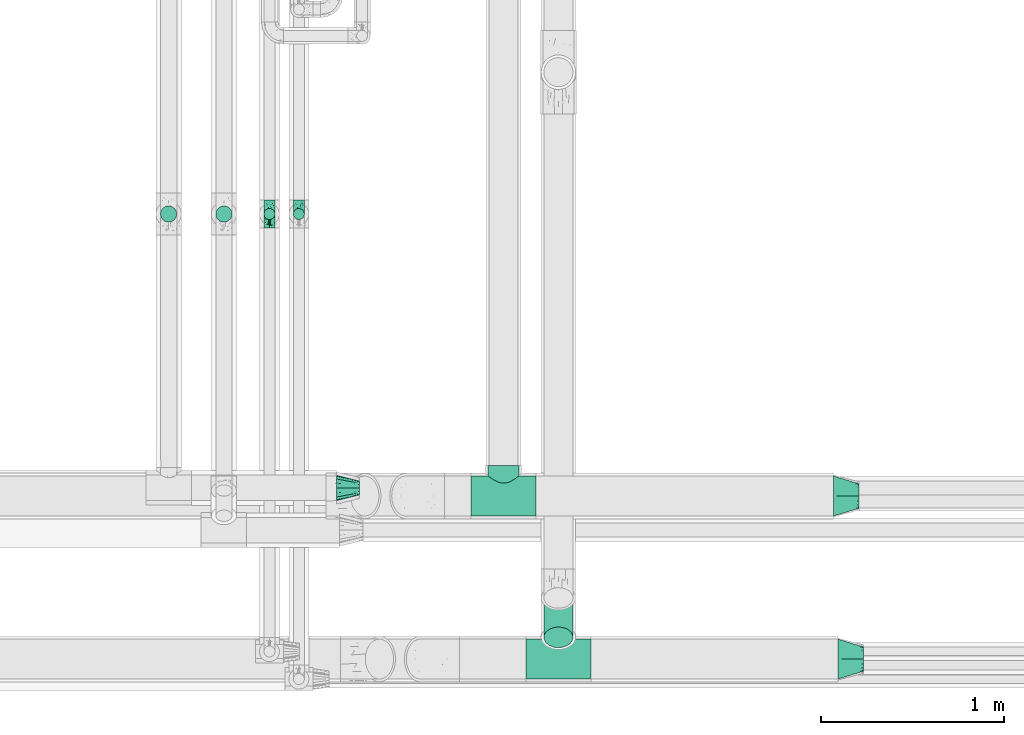
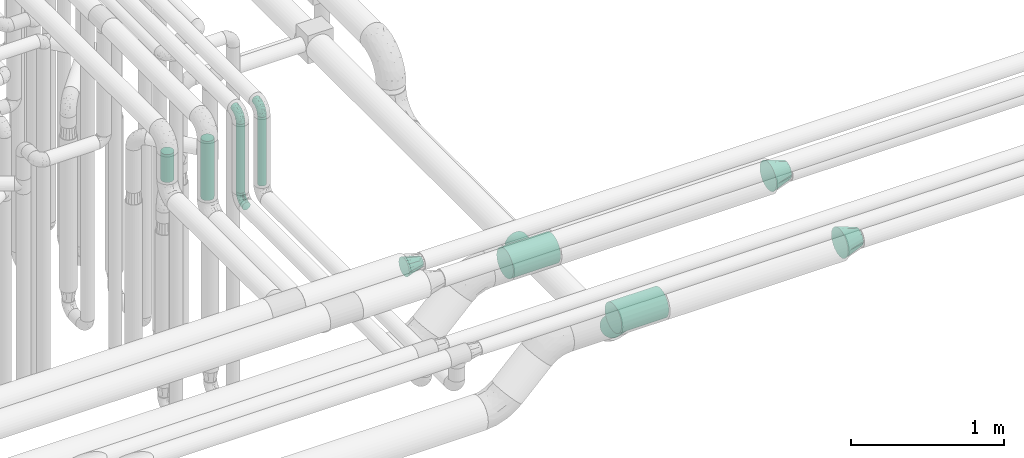
# One storey, part 604 of 824: 8 flow fittings, 5 flow segments.
"""IFC2X3 building model written with IfcOpenShell, lengths in millimetres."""

from ifc_helpers import new_model, entity, si_unit, converted_unit, derived_unit, direction, frame, origin, origin_2d_with_axis, place, context, subcontext, project, spatial, circle, extrude, faceted_brep, source, transform, mapped, material, type_object, type_shapes, element, save


model = new_model("IFC2X3")

# Units and contexts
model_context = context("Model", 3, precision=0.01, world=origin(), true_north=direction((6.12303176911189e-17, 1.0)))
body_context = subcontext(model_context, "Body", "Model", "MODEL_VIEW")
ifc_project = project(units=[si_unit("LENGTHUNIT", "METRE", prefix="MILLI"), si_unit("AREAUNIT", "SQUARE_METRE"), si_unit("VOLUMEUNIT", "CUBIC_METRE"), converted_unit("PLANEANGLEUNIT", "DEGREE", entity("IfcRatioMeasure", 0.0174532925199433), si_unit("PLANEANGLEUNIT", "RADIAN"), dimensions=[0, 0, 0, 0, 0, 0, 0]), si_unit("MASSUNIT", "GRAM", prefix="KILO"), derived_unit("MASSDENSITYUNIT", [(si_unit("MASSUNIT", "GRAM", prefix="KILO"), 1), (si_unit("LENGTHUNIT", "METRE"), -3)]), derived_unit("MOMENTOFINERTIAUNIT", [(si_unit("LENGTHUNIT", "METRE"), 4)]), si_unit("TIMEUNIT", "SECOND"), si_unit("FREQUENCYUNIT", "HERTZ"), si_unit("THERMODYNAMICTEMPERATUREUNIT", "DEGREE_CELSIUS"), derived_unit("THERMALTRANSMITTANCEUNIT", [(si_unit("MASSUNIT", "GRAM", prefix="KILO"), 1), (si_unit("THERMODYNAMICTEMPERATUREUNIT", "KELVIN"), -1), (si_unit("TIMEUNIT", "SECOND"), -3)]), derived_unit("VOLUMETRICFLOWRATEUNIT", [(si_unit("LENGTHUNIT", "METRE"), 3), (si_unit("TIMEUNIT", "SECOND"), -1)]), derived_unit("MASSFLOWRATEUNIT", [(si_unit("MASSUNIT", "GRAM", prefix="KILO"), 1), (si_unit("TIMEUNIT", "SECOND"), -1)]), derived_unit("ROTATIONALFREQUENCYUNIT", [(si_unit("TIMEUNIT", "SECOND"), -1)]), si_unit("ELECTRICCURRENTUNIT", "AMPERE"), si_unit("ELECTRICVOLTAGEUNIT", "VOLT"), si_unit("POWERUNIT", "WATT"), si_unit("FORCEUNIT", "NEWTON", prefix="KILO"), si_unit("ILLUMINANCEUNIT", "LUX"), si_unit("LUMINOUSFLUXUNIT", "LUMEN"), si_unit("LUMINOUSINTENSITYUNIT", "CANDELA"), derived_unit("USERDEFINED", [(si_unit("MASSUNIT", "GRAM", prefix="KILO"), -1), (si_unit("LENGTHUNIT", "METRE"), -2), (si_unit("TIMEUNIT", "SECOND"), 3), (si_unit("LUMINOUSFLUXUNIT", "LUMEN"), 1)]), derived_unit("LINEARVELOCITYUNIT", [(si_unit("LENGTHUNIT", "METRE"), 1), (si_unit("TIMEUNIT", "SECOND"), -1)]), si_unit("PRESSUREUNIT", "PASCAL"), derived_unit("USERDEFINED", [(si_unit("LENGTHUNIT", "METRE"), -2), (si_unit("MASSUNIT", "GRAM", prefix="KILO"), 1), (si_unit("TIMEUNIT", "SECOND"), -2)]), derived_unit("LINEARFORCEUNIT", [(si_unit("MASSUNIT", "GRAM", prefix="KILO"), 1), (si_unit("LENGTHUNIT", "METRE"), 1), (si_unit("TIMEUNIT", "SECOND"), -2), (si_unit("LENGTHUNIT", "METRE"), -1)]), derived_unit("PLANARFORCEUNIT", [(si_unit("MASSUNIT", "GRAM", prefix="KILO"), 1), (si_unit("LENGTHUNIT", "METRE"), 1), (si_unit("TIMEUNIT", "SECOND"), -2), (si_unit("LENGTHUNIT", "METRE"), -2)])], contexts=[model_context])

# Site, building, storey
site_placement = place(None, origin())
site = spatial("IfcSite", under=ifc_project, at=site_placement, CompositionType="ELEMENT")
building_placement = place(site_placement, origin())
building = spatial("IfcBuilding", under=site, at=building_placement, CompositionType="ELEMENT")
storey_placement = place(building_placement, frame((0.0, 0.0, 28200.0)))
storey = spatial("IfcBuildingStorey", under=building, at=storey_placement, CompositionType="ELEMENT", Elevation=28200.0)

# Flow segments
pipe_segment_type_1 = type_object("IfcPipeSegmentType", PredefinedType="NOTDEFINED")
flow_segment_1_placement = place(storey_placement, frame((37967.2, 6435.98, 2508.09)))
element("IfcFlowSegment", 1, at=flow_segment_1_placement, inside=storey, type_object=pipe_segment_type_1, context=body_context, shape_type="SweptSolid", body=[
    extrude(circle(Radius=79.5, at=origin_2d_with_axis()), frame((81.1, 57.81, 273.12), z_axis=(0.0, 0.707106781186546, -0.707106781186549), x_axis=(1.0, 0.0, 0.0)), (0.0, 0.0, 1.0), 304.487373415324),
])
pipe_segment_type_2 = type_object("IfcPipeSegmentType", PredefinedType="NOTDEFINED")
flow_segment_2_placement = place(storey_placement, frame((36174.19, 8761.54, 2964.0)))
element("IfcFlowSegment", 2, at=flow_segment_2_placement, inside=storey, type_object=pipe_segment_type_2, context=body_context, shape_type="SweptSolid", body=[
    extrude(circle(Radius=44.25, at=origin_2d_with_axis()), frame((45.85, 45.85, 0.0), z_axis=(0.0, 0.0, 1.0), x_axis=(-1.0, 0.0, 0.0)), (0.0, 0.0, 1.0), 472.000402937329),
])
flow_segment_3_placement = place(storey_placement, frame((35872.22, 8761.54, 3214.0)))
element("IfcFlowSegment", 3, at=flow_segment_3_placement, inside=storey, type_object=pipe_segment_type_2, context=body_context, shape_type="SweptSolid", body=[
    extrude(circle(Radius=44.25, at=origin_2d_with_axis()), frame((45.85, 45.85, 0.0)), (0.0, 0.0, 1.0), 222.001032735806),
])
flow_segment_4_placement = place(storey_placement, frame((36598.05, 8775.79, 2926.0)))
element("IfcFlowSegment", 4, at=flow_segment_4_placement, inside=storey, type_object=pipe_segment_type_2, context=body_context, shape_type="SweptSolid", body=[
    extrude(circle(Radius=30.0, at=origin_2d_with_axis()), frame((31.6, 31.6, 0.0)), (0.0, 0.0, 1.0), 547.999328702734),
])
flow_segment_5_placement = place(storey_placement, frame((36437.12, 8775.79, 2926.0)))
element("IfcFlowSegment", 5, at=flow_segment_5_placement, inside=storey, type_object=pipe_segment_type_2, context=body_context, shape_type="SweptSolid", body=[
    extrude(circle(Radius=30.0, at=origin_2d_with_axis()), frame((31.6, 31.6, 0.0), z_axis=(0.0, 0.0, 1.0), x_axis=(-1.0, 0.0, 0.0)), (0.0, 0.0, 1.0), 548.000000000049),
])

# Flow fittings
ifc_material = material()
pipe_fitting_type_1 = type_object("IfcPipeFittingType", PredefinedType="NOTDEFINED", material=ifc_material)
shared_shape_1 = source(origin(), body_context, "Body", "Brep", [
    faceted_brep([(-76.0, 15.07, -26.11), (-76.0, 7.8, -29.12), (-76.0, 0.0, -30.15), (-76.0, -7.8, -29.12), (-76.0, -15.08, -26.11), (-76.0, -21.32, -21.32), (-76.0, -26.11, -15.08), (-76.0, -29.12, -7.8), (-76.0, -30.15, 0.0), (-76.0, -29.12, 7.8), (-76.0, -26.11, 15.07), (-76.0, -21.32, 21.32), (-76.0, -15.08, 26.11), (-76.0, -7.8, 29.12), (-76.0, 0.0, 30.15), (-76.0, 7.8, 29.12), (-76.0, 15.07, 26.11), (-76.0, 21.32, 21.32), (-76.0, 26.11, 15.07), (-76.0, 29.12, 7.8), (-76.0, 30.15, 0.0), (-76.0, 29.12, -7.8), (-76.0, 26.11, -15.08), (-76.0, 21.32, -21.32), (0.0, 76.0, -30.15), (-7.8, 76.0, -29.12), (-15.07, 76.0, -26.11), (-21.32, 76.0, -21.32), (-26.11, 76.0, -15.08), (-29.12, 76.0, -7.8), (-30.15, 76.0, 0.0), (-29.12, 76.0, 7.8), (-26.11, 76.0, 15.07), (-21.32, 76.0, 21.32), (-15.07, 76.0, 26.11), (-7.8, 76.0, 29.12), (0.0, 76.0, 30.15), (7.8, 76.0, 29.12), (15.08, 76.0, 26.11), (21.32, 76.0, 21.32), (26.11, 76.0, 15.07), (29.12, 76.0, 7.8), (30.15, 76.0, 0.0), (29.12, 76.0, -7.8), (26.11, 76.0, -15.08), (21.32, 76.0, -21.32), (15.08, 76.0, -26.11), (7.8, 76.0, -29.12), (10.79, 31.43, 21.07), (4.32, 31.7, 25.72), (1.65, 15.19, 19.92), (-61.17, -27.8, 0.0), (-51.1, -25.49, 9.84), (-56.14, -10.61, 27.27), (-31.7, -4.32, 25.72), (-39.75, 1.72, 29.41), (-43.2, -24.95, 0.0), (-1.86, 1.86, 0.0), (4.49, 7.65, 5.78), (-7.82, -4.61, 5.83), (-56.21, -22.79, 17.21), (-58.98, -3.38, 29.7), (-53.96, 5.6, 30.07), (-10.86, 10.86, 25.48), (-17.2, -2.6, 20.44), (-49.15, -16.01, 22.7), (-22.18, -14.24, 7.99), (-28.4, -17.42, 0.0), (-13.61, -9.88, 0.0), (-39.0, 23.48, 27.76), (-58.76, 12.54, 28.36), (-41.61, 15.41, 29.48), (16.01, 49.15, 22.7), (-58.55, 25.93, 19.53), (-51.53, 33.5, 13.51), (-64.92, 28.76, 12.4), (-7.48, 23.14, 28.25), (-1.72, 39.75, 29.41), (-12.04, 27.88, 29.88), (-63.91, 18.81, 24.52), (-11.63, 65.16, 28.18), (-4.97, 57.02, 30.05), (9.88, 13.61, 0.0), (-62.5, 31.74, 5.02), (-45.17, 30.98, 21.2), (-21.78, 9.76, 28.58), (10.61, 56.14, 27.27), (-32.09, 54.42, 13.26), (22.79, 56.21, 17.21), (15.38, 31.17, 15.63), (25.49, 51.1, 9.84), (21.84, 36.35, 5.92), (24.95, 43.2, 0.0), (3.38, 58.98, 29.7), (-31.17, -15.38, 15.63), (-39.39, 41.78, 15.45), (-34.56, 41.13, 20.79), (-39.81, -23.25, 5.49), (27.8, 61.17, 0.0), (-31.74, 62.5, 5.02), (-53.07, 36.29, 0.0), (-42.95, 42.95, 7.29), (-36.29, 53.07, 0.0), (-19.83, 58.51, 24.79), (-25.48, 60.2, 19.41), (-14.53, 50.96, 28.57), (-13.31, 37.09, 30.07), (-26.16, 40.06, 26.4), (-32.43, -10.35, 21.9), (17.42, 28.4, 0.0), (14.24, 22.18, 7.99), (-38.67, 9.72, 30.15), (-24.66, 17.36, 30.09), (-37.08, 31.49, 24.99), (-49.27, 22.83, 25.24), (-20.8, 38.81, 28.63), (-27.58, 27.58, 29.2), (-36.07, -20.23, 10.71), (-15.19, -6.16, 14.9), (6.6, 15.4, 14.49), (-2.51, 2.51, 11.35), (-65.16, 11.63, -28.18), (-49.15, -16.01, -22.7), (-57.02, 4.97, -30.05), (-25.93, 58.55, -19.53), (-33.5, 51.53, -13.51), (-28.76, 64.92, -12.4), (-60.2, 25.48, -19.41), (-58.51, 19.83, -24.79), (4.61, 7.82, -5.83), (-7.65, -4.49, -5.78), (-2.51, 2.51, -11.35), (-62.5, 31.74, -5.02), (-50.96, 14.53, -28.57), (-37.09, 13.31, -30.07), (-42.95, 42.95, -7.29), (25.49, 51.1, -9.84), (22.79, 56.21, -17.21), (-40.06, 26.16, -26.4), (3.38, 58.98, -29.7), (-5.6, 53.96, -30.07), (-27.88, 12.04, -29.88), (-9.76, 21.78, -28.58), (-23.14, 7.48, -28.25), (-51.1, -25.49, -9.84), (15.38, 31.17, -15.63), (16.01, 49.15, -22.7), (-23.48, 39.0, -27.76), (-12.54, 58.76, -28.36), (-15.41, 41.61, -29.48), (-56.21, -22.79, -17.21), (-9.72, 38.67, -30.15), (-17.36, 24.66, -30.09), (-22.18, -14.24, -7.99), (-41.13, 34.56, -20.79), (-31.74, 62.5, -5.02), (-58.98, -3.38, -29.7), (-31.17, -15.38, -15.63), (-56.14, -10.61, -27.27), (14.24, 22.18, -7.99), (23.25, 39.81, -5.49), (-31.49, 37.08, -24.99), (-15.19, -6.16, -14.9), (1.65, 15.19, -19.92), (-18.81, 63.91, -24.52), (-32.59, -11.62, -20.84), (-31.7, -4.32, -25.72), (-17.2, -2.6, -20.44), (-39.75, 1.72, -29.41), (-54.42, 32.09, -13.26), (-30.98, 45.17, -21.2), (10.61, 56.14, -27.27), (10.23, 31.31, -21.52), (4.32, 31.7, -25.72), (-41.78, 39.39, -15.45), (-1.72, 39.75, -29.41), (-36.35, -21.84, -5.92), (-22.83, 49.27, -25.24), (-38.81, 20.8, -28.63), (-27.58, 27.58, -29.2), (-10.86, 10.86, -25.48), (20.23, 36.07, -10.71), (6.6, 15.4, -14.49)], [[[0, 1, 2, 3, 4, 5, 6, 7, 8, 9, 10, 11, 12, 13, 14, 15, 16, 17, 18, 19, 20, 21, 22, 23]], [[24, 25, 26, 27, 28, 29, 30, 31, 32, 33, 34, 35, 36, 37, 38, 39, 40, 41, 42, 43, 44, 45, 46, 47]], [[48, 49, 50]], [[51, 52, 9]], [[53, 54, 55]], [[9, 52, 10]], [[56, 52, 51]], [[57, 58, 59]], [[11, 10, 60]], [[14, 61, 62]], [[63, 54, 64]], [[65, 12, 11]], [[65, 53, 12]], [[66, 67, 68]], [[69, 70, 71]], [[72, 39, 38]], [[73, 74, 75]], [[15, 70, 16]], [[76, 77, 78]], [[16, 79, 17]], [[13, 61, 14]], [[35, 80, 81]], [[14, 62, 15]], [[17, 73, 18]], [[57, 82, 58]], [[20, 19, 83]], [[75, 19, 18]], [[70, 15, 62]], [[73, 84, 74]], [[78, 85, 76]], [[38, 86, 72]], [[32, 31, 87]], [[88, 89, 90]], [[91, 92, 90]], [[72, 86, 49]], [[36, 93, 37]], [[75, 83, 19]], [[36, 35, 81]], [[60, 94, 65]], [[40, 90, 41]], [[95, 96, 87]], [[88, 90, 40]], [[66, 97, 67]], [[90, 98, 41]], [[40, 39, 88]], [[99, 31, 30]], [[20, 83, 100]], [[101, 102, 100]], [[52, 60, 10]], [[102, 99, 30]], [[96, 103, 104]], [[83, 101, 100]], [[12, 53, 13]], [[104, 103, 33]], [[105, 106, 81]], [[107, 105, 103]], [[64, 54, 108]], [[80, 103, 105]], [[80, 35, 34]], [[34, 33, 103]], [[86, 38, 37]], [[109, 110, 82]], [[71, 111, 112]], [[69, 107, 113]], [[79, 73, 17]], [[114, 113, 84]], [[33, 32, 104]], [[115, 107, 116]], [[105, 115, 106]], [[93, 81, 77]], [[54, 53, 65]], [[61, 53, 55]], [[108, 94, 64]], [[54, 63, 85]], [[93, 86, 37]], [[77, 76, 49]], [[77, 49, 86]], [[49, 63, 50]], [[60, 52, 117]], [[65, 11, 60]], [[39, 72, 88]], [[89, 88, 72]], [[71, 70, 62]], [[79, 70, 114]], [[103, 96, 107]], [[69, 113, 114]], [[112, 106, 116]], [[77, 81, 106]], [[112, 116, 71]], [[112, 55, 85]], [[64, 50, 63]], [[57, 59, 68]], [[32, 87, 104]], [[96, 104, 87]], [[94, 118, 64]], [[50, 119, 89]], [[50, 64, 118]], [[50, 89, 48]], [[81, 93, 36]], [[86, 93, 77]], [[53, 61, 13]], [[62, 61, 55]], [[71, 62, 111]], [[69, 71, 116]], [[95, 101, 74]], [[99, 101, 87]], [[118, 66, 59]], [[117, 97, 66]], [[117, 66, 94]], [[91, 89, 110]], [[91, 110, 109]], [[110, 89, 119]], [[9, 8, 51]], [[98, 90, 92]], [[98, 42, 41]], [[101, 83, 74]], [[101, 99, 102]], [[87, 31, 99]], [[62, 55, 111]], [[55, 112, 111]], [[107, 69, 116]], [[70, 69, 114]], [[107, 96, 113]], [[84, 113, 96]], [[84, 96, 95]], [[114, 84, 73]], [[70, 79, 16]], [[73, 79, 114]], [[54, 85, 55]], [[76, 85, 63]], [[49, 76, 63]], [[77, 106, 78]], [[106, 112, 78]], [[85, 78, 112]], [[73, 75, 18]], [[83, 75, 74]], [[103, 80, 34]], [[81, 80, 105]], [[101, 95, 87]], [[84, 95, 74]], [[106, 115, 116]], [[105, 107, 115]], [[120, 59, 58]], [[82, 110, 58]], [[119, 58, 110]], [[118, 59, 120]], [[66, 68, 59]], [[54, 65, 108]], [[94, 108, 65]], [[66, 118, 94]], [[50, 118, 120]], [[50, 120, 119]], [[119, 120, 58]], [[89, 72, 48]], [[49, 48, 72]], [[60, 117, 94]], [[117, 52, 97]], [[52, 56, 97]], [[67, 97, 56]], [[92, 91, 109]], [[89, 91, 90]], [[121, 1, 0]], [[122, 5, 4]], [[2, 1, 123]], [[124, 125, 126]], [[127, 128, 23]], [[129, 130, 131]], [[100, 132, 20]], [[133, 134, 123]], [[135, 100, 102]], [[136, 137, 44]], [[133, 128, 138]], [[24, 139, 140]], [[141, 142, 143]], [[121, 128, 133]], [[6, 144, 7]], [[137, 145, 146]], [[144, 51, 7]], [[147, 148, 149]], [[144, 6, 150]], [[149, 151, 152]], [[153, 68, 67]], [[154, 128, 127]], [[30, 155, 102]], [[43, 42, 98]], [[156, 3, 2]], [[157, 144, 150]], [[158, 4, 3]], [[24, 140, 25]], [[155, 135, 102]], [[159, 160, 109]], [[30, 29, 155]], [[147, 138, 161]], [[27, 124, 28]], [[57, 129, 82]], [[162, 163, 131]], [[27, 26, 164]], [[148, 26, 25]], [[165, 166, 167]], [[24, 47, 139]], [[143, 168, 141]], [[22, 21, 169]], [[125, 124, 170]], [[148, 25, 140]], [[46, 146, 171]], [[158, 122, 4]], [[0, 23, 128]], [[1, 121, 123]], [[109, 82, 159]], [[45, 44, 137]], [[146, 46, 45]], [[136, 43, 98]], [[132, 21, 20]], [[136, 98, 92]], [[172, 173, 146]], [[46, 171, 47]], [[43, 136, 44]], [[174, 154, 169]], [[171, 173, 175]], [[6, 5, 150]], [[126, 29, 28]], [[176, 56, 144]], [[122, 158, 166]], [[164, 124, 27]], [[177, 161, 170]], [[23, 22, 127]], [[178, 138, 179]], [[133, 178, 134]], [[156, 123, 168]], [[156, 158, 3]], [[168, 143, 166]], [[168, 166, 158]], [[166, 180, 167]], [[173, 171, 146]], [[139, 171, 175]], [[172, 145, 163]], [[173, 180, 142]], [[5, 122, 150]], [[157, 150, 122]], [[137, 136, 181]], [[146, 45, 137]], [[149, 148, 140]], [[164, 148, 177]], [[128, 154, 138]], [[147, 161, 177]], [[152, 134, 179]], [[168, 123, 134]], [[152, 179, 149]], [[152, 175, 142]], [[57, 130, 129]], [[157, 165, 167]], [[22, 169, 127]], [[154, 127, 169]], [[163, 167, 180]], [[162, 157, 167]], [[173, 163, 180]], [[182, 163, 145]], [[123, 156, 2]], [[158, 156, 168]], [[171, 139, 47]], [[140, 139, 175]], [[149, 140, 151]], [[147, 149, 179]], [[174, 135, 125]], [[132, 135, 169]], [[176, 157, 153]], [[176, 153, 67]], [[153, 157, 162]], [[182, 159, 129]], [[181, 160, 159]], [[181, 159, 145]], [[51, 144, 56]], [[51, 8, 7]], [[135, 132, 100]], [[169, 21, 132]], [[126, 155, 29]], [[135, 155, 125]], [[140, 175, 151]], [[175, 152, 151]], [[138, 147, 179]], [[148, 147, 177]], [[138, 154, 161]], [[170, 161, 154]], [[170, 154, 174]], [[177, 170, 124]], [[148, 164, 26]], [[124, 164, 177]], [[173, 142, 175]], [[143, 142, 180]], [[166, 143, 180]], [[168, 134, 141]], [[134, 152, 141]], [[142, 141, 152]], [[124, 126, 28]], [[155, 126, 125]], [[128, 121, 0]], [[123, 121, 133]], [[135, 174, 169]], [[170, 174, 125]], [[134, 178, 179]], [[133, 138, 178]], [[130, 153, 162]], [[68, 153, 130]], [[57, 68, 130]], [[182, 129, 131]], [[159, 82, 129]], [[157, 122, 165]], [[166, 165, 122]], [[163, 162, 167]], [[162, 131, 130]], [[145, 172, 146]], [[163, 173, 172]], [[159, 182, 145]], [[131, 163, 182]], [[56, 176, 67]], [[157, 176, 144]], [[137, 181, 145]], [[181, 136, 160]], [[136, 92, 160]], [[109, 160, 92]]]),
])
type_shapes(pipe_fitting_type_1, [shared_shape_1])
for number, where, z_axis, x_axis in (
    (6, (36468.72, 8807.39, 2850.0), (1.0, 0.0, 0.0), (0.0, 1.0, 0.0)),
    (7, (36468.72, 8807.39, 3550.0), (-1.0, 0.0, 0.0), (0.0, 0.0, 1.0)),
    (8, (36629.64, 8807.39, 3550.0), (1.0, 0.0, 0.0), (0.0, -1.0, 0.0)),
):
    element("IfcFlowFitting", number, at=place(storey_placement, frame(where, z_axis=z_axis, x_axis=x_axis)), inside=storey, type_object=pipe_fitting_type_1, material=ifc_material, context=body_context, shape_type="MappedRepresentation", body=[
        mapped(shared_shape_1, transform((0.0, 0.0, 0.0), scale=1.0)),
    ])
pipe_fitting_type_2 = type_object("IfcPipeFittingType", PredefinedType="NOTDEFINED", material=ifc_material)
shared_shape_2 = source(origin(), body_context, "Body", "Brep", [
    faceted_brep([(127.0, 32.95, 19.03), (127.0, 25.99, 25.99), (127.0, 19.02, 32.95), (127.0, 9.51, 35.5), (127.0, 0.0, 38.05), (127.0, -9.51, 35.5), (127.0, -19.03, 32.95), (127.0, -25.99, 25.99), (127.0, -32.95, 19.03), (127.0, -35.5, 9.51), (127.0, -38.05, 0.0), (127.0, -35.5, -9.51), (127.0, -32.95, -19.02), (127.0, -25.99, -25.99), (127.0, -19.03, -32.95), (127.0, -9.51, -35.5), (127.0, 0.0, -38.05), (127.0, 9.51, -35.5), (127.0, 19.02, -32.95), (127.0, 25.99, -25.99), (127.0, 32.95, -19.02), (127.0, 35.5, -9.51), (127.0, 38.05, 0.0), (127.0, 35.5, 9.51), (0.0, 38.06, 56.96), (0.0, 49.39, 49.39), (0.0, 56.96, 38.06), (0.0, 64.53, 26.73), (0.0, 67.19, 13.37), (0.0, 69.85, 0.0), (0.0, 67.19, -13.37), (0.0, 64.53, -26.73), (0.0, 56.96, -38.06), (0.0, 49.39, -49.39), (0.0, 38.06, -56.96), (0.0, 26.73, -64.53), (0.0, 13.37, -67.19), (0.0, 0.0, -69.85), (0.0, -13.37, -67.19), (0.0, -26.73, -64.53), (0.0, -38.06, -56.96), (0.0, -49.39, -49.39), (0.0, -56.96, -38.06), (0.0, -64.53, -26.73), (0.0, -67.19, -13.37), (0.0, -69.85, 0.0), (0.0, -67.19, 13.37), (0.0, -64.53, 26.73), (0.0, -56.96, 38.06), (0.0, -49.39, 49.39), (0.0, -38.06, 56.96), (0.0, -26.73, 64.53), (0.0, -13.37, 67.19), (0.0, 0.0, 69.85), (0.0, 13.37, 67.19), (0.0, 26.73, 64.53)], [[[0, 1, 2, 3, 4, 5, 6, 7, 8, 9, 10, 11, 12, 13, 14, 15, 16, 17, 18, 19, 20, 21, 22, 23]], [[24, 25, 26, 27, 28, 29, 30, 31, 32, 33, 34, 35, 36, 37, 38, 39, 40, 41, 42, 43, 44, 45, 46, 47, 48, 49, 50, 51, 52, 53, 54, 55]], [[30, 29, 22]], [[16, 15, 38]], [[18, 35, 34]], [[15, 39, 38]], [[13, 12, 42]], [[13, 40, 14]], [[16, 36, 17]], [[40, 13, 41]], [[35, 18, 17]], [[21, 31, 30]], [[19, 32, 20]], [[19, 18, 34]], [[19, 34, 33]], [[40, 39, 14]], [[15, 14, 39]], [[38, 37, 16]], [[21, 20, 31]], [[12, 43, 42]], [[44, 10, 45]], [[32, 19, 33]], [[22, 21, 30]], [[10, 44, 11]], [[42, 41, 13]], [[32, 31, 20]], [[36, 35, 17]], [[43, 12, 11]], [[44, 43, 11]], [[36, 16, 37]], [[46, 45, 10]], [[4, 3, 54]], [[6, 51, 50]], [[3, 55, 54]], [[1, 0, 26]], [[1, 24, 2]], [[4, 52, 5]], [[24, 1, 25]], [[51, 6, 5]], [[9, 47, 46]], [[7, 48, 8]], [[7, 6, 50]], [[7, 50, 49]], [[24, 55, 2]], [[3, 2, 55]], [[54, 53, 4]], [[9, 8, 47]], [[0, 27, 26]], [[28, 22, 29]], [[48, 7, 49]], [[10, 9, 46]], [[22, 28, 23]], [[26, 25, 1]], [[48, 47, 8]], [[52, 51, 5]], [[27, 0, 23]], [[28, 27, 23]], [[52, 4, 53]]]),
])
type_shapes(pipe_fitting_type_2, [shared_shape_2])
flow_fitting_placement = place(storey_placement, frame((36835.03, 7310.0, 3100.0)))
element("IfcFlowFitting", 9, at=flow_fitting_placement, inside=storey, type_object=pipe_fitting_type_2, material=ifc_material, context=body_context, shape_type="MappedRepresentation", body=[
    mapped(shared_shape_2, transform((0.0, 0.0, 0.0), scale=1.0)),
])
pipe_fitting_type_3 = type_object("IfcPipeFittingType", PredefinedType="NOTDEFINED", material=ifc_material)
shared_shape_3 = source(origin(), body_context, "Body", "Brep", [
    faceted_brep([(-178.0, 0.0, -109.55), (-178.0, -28.35, -105.82), (-178.0, -54.78, -94.87), (-178.0, -77.46, -77.46), (-178.0, -86.17, -66.12), (-178.0, -94.87, -54.78), (-178.0, -100.35, -41.56), (-178.0, -105.82, -28.35), (-178.0, -107.68, -14.18), (-178.0, -109.55, 0.0), (-178.0, -107.68, 14.18), (-178.0, -105.82, 28.35), (-178.0, -100.35, 41.56), (-178.0, -94.87, 54.77), (-178.0, -86.17, 66.12), (-178.0, -77.46, 77.46), (-178.0, -54.78, 94.87), (-178.0, -28.35, 105.82), (-178.0, 0.0, 109.55), (-178.0, 28.35, 105.82), (-178.0, 54.77, 94.87), (-178.0, 77.46, 77.46), (-178.0, 94.87, 54.77), (-178.0, 105.82, 28.35), (-178.0, 109.55, 0.0), (-178.0, 105.82, -28.35), (-178.0, 94.87, -54.78), (-178.0, 77.46, -77.46), (-178.0, 54.77, -94.87), (-178.0, 28.35, -105.82), (178.0, 0.0, -109.55), (178.0, 28.35, -105.82), (178.0, 54.77, -94.87), (178.0, 77.46, -77.46), (178.0, 94.87, -54.78), (178.0, 105.82, -28.35), (178.0, 109.55, 0.0), (178.0, 105.82, 28.35), (178.0, 94.87, 54.77), (178.0, 77.46, 77.46), (178.0, 54.77, 94.87), (178.0, 28.35, 105.82), (178.0, 0.0, 109.55), (178.0, -28.35, 105.82), (178.0, -54.78, 94.87), (178.0, -77.46, 77.46), (178.0, -86.17, 66.12), (178.0, -94.87, 54.77), (178.0, -100.35, 41.56), (178.0, -105.82, 28.35), (178.0, -107.68, 14.18), (178.0, -109.55, 0.0), (178.0, -107.68, -14.18), (178.0, -105.82, -28.35), (178.0, -100.35, -41.56), (178.0, -94.87, -54.78), (178.0, -86.17, -66.12), (178.0, -77.46, -77.46), (178.0, -54.78, -94.87), (178.0, -28.35, -105.82), (82.88, -108.58, 14.54), (84.15, -109.55, 0.0), (-84.15, -109.55, 0.0), (79.21, -105.8, 28.42), (73.4, -101.53, 41.15), (65.81, -96.18, 52.45), (56.69, -90.19, 62.19), (46.22, -84.0, 70.32), (34.46, -78.15, 76.77), (-79.21, -105.8, 28.42), (-73.4, -101.53, 41.15), (-82.88, -108.58, 14.54), (-46.22, -84.0, 70.32), (-34.46, -78.15, 76.77), (-56.69, -90.19, 62.19), (-65.8, -96.18, 52.45), (-21.44, -73.35, 81.37), (21.44, -73.35, 81.37), (7.31, -70.52, 83.83), (-7.31, -70.52, 83.83), (21.44, -73.35, -81.37), (7.31, -70.52, -83.83), (-82.88, -108.58, -14.54), (-73.4, -101.53, -41.15), (-7.31, -70.52, -83.83), (-21.44, -73.35, -81.37), (-34.46, -78.15, -76.77), (-56.69, -90.19, -62.19), (56.69, -90.19, -62.19), (46.22, -84.0, -70.32), (65.81, -96.18, -52.45), (34.46, -78.15, -76.77), (82.88, -108.58, -14.54), (79.21, -105.8, -28.42), (73.4, -101.53, -41.15), (-46.22, -84.0, -70.32), (-65.8, -96.18, -52.45), (-79.21, -105.8, -28.42), (0.0, -168.0, -84.15), (21.78, -168.0, -81.28), (42.08, -168.0, -72.88), (59.5, -168.0, -59.5), (72.88, -168.0, -42.08), (81.28, -168.0, -21.78), (84.15, -168.0, 0.0), (81.28, -168.0, 21.78), (72.88, -168.0, 42.07), (59.5, -168.0, 59.5), (42.08, -168.0, 72.88), (21.78, -168.0, 81.28), (0.0, -168.0, 84.15), (-21.78, -168.0, 81.28), (-42.07, -168.0, 72.88), (-59.5, -168.0, 59.5), (-72.88, -168.0, 42.07), (-81.28, -168.0, 21.78), (-84.15, -168.0, 0.0), (-81.28, -168.0, -21.78), (-72.88, -168.0, -42.08), (-59.5, -168.0, -59.5), (-42.07, -168.0, -72.88), (-21.78, -168.0, -81.28)], [[[0, 1, 2, 3, 4, 5, 6, 7, 8, 9, 10, 11, 12, 13, 14, 15, 16, 17, 18, 19, 20, 21, 22, 23, 24, 25, 26, 27, 28, 29]], [[30, 31, 32, 33, 34, 35, 36, 37, 38, 39, 40, 41, 42, 43, 44, 45, 46, 47, 48, 49, 50, 51, 52, 53, 54, 55, 56, 57, 58, 59]], [[50, 49, 60]], [[61, 51, 50]], [[62, 10, 9]], [[63, 60, 49]], [[49, 64, 63]], [[48, 65, 64]], [[65, 48, 47]], [[65, 47, 66]], [[67, 66, 46]], [[45, 68, 67]], [[67, 46, 45]], [[64, 49, 48]], [[69, 70, 11]], [[71, 69, 11]], [[10, 62, 71]], [[70, 12, 11]], [[72, 73, 15]], [[72, 15, 14]], [[74, 13, 75]], [[13, 74, 14]], [[13, 12, 75]], [[15, 73, 76]], [[66, 47, 46]], [[61, 50, 60]], [[17, 16, 44, 43]], [[77, 45, 78]], [[44, 78, 45]], [[71, 11, 10]], [[18, 17, 43, 42]], [[22, 21, 39, 38]], [[23, 22, 38, 37]], [[20, 19, 41, 40]], [[21, 20, 40, 39]], [[41, 19, 18, 42]], [[24, 23, 37, 36]], [[75, 12, 70]], [[72, 14, 74]], [[79, 78, 16]], [[79, 16, 15]], [[44, 16, 78]], [[79, 15, 76]], [[77, 68, 45]], [[33, 27, 26, 34]], [[35, 25, 24, 36]], [[35, 34, 26, 25]], [[28, 27, 33, 32]], [[59, 1, 0, 30]], [[58, 2, 1, 59]], [[31, 30, 0, 29]], [[80, 81, 57]], [[62, 8, 82]], [[32, 31, 29, 28]], [[81, 58, 57]], [[81, 2, 58]], [[83, 7, 6]], [[3, 84, 85]], [[2, 84, 3]], [[3, 85, 86]], [[84, 2, 81]], [[87, 5, 4]], [[56, 55, 88]], [[89, 57, 56]], [[90, 88, 55]], [[54, 90, 55]], [[57, 89, 91]], [[52, 51, 61]], [[8, 62, 9]], [[52, 61, 92]], [[93, 94, 53]], [[92, 93, 53]], [[53, 94, 54]], [[90, 54, 94]], [[92, 53, 52]], [[4, 95, 87]], [[89, 56, 88]], [[87, 96, 5]], [[96, 83, 6]], [[3, 95, 4]], [[95, 3, 86]], [[97, 82, 7]], [[83, 97, 7]], [[82, 8, 7]], [[6, 5, 96]], [[91, 80, 57]], [[98, 99, 100, 101, 102, 103, 104, 105, 106, 107, 108, 109, 110, 111, 112, 113, 114, 115, 116, 117, 118, 119, 120, 121]], [[116, 115, 71]], [[71, 62, 116]], [[71, 115, 69]], [[113, 112, 74]], [[75, 114, 113]], [[69, 115, 114]], [[73, 112, 111]], [[70, 69, 114]], [[75, 113, 74]], [[114, 75, 70]], [[72, 112, 73]], [[76, 73, 111]], [[74, 112, 72]], [[79, 76, 111]], [[111, 110, 79]], [[108, 68, 109]], [[109, 78, 110]], [[66, 108, 107]], [[60, 105, 104]], [[107, 106, 65]], [[105, 63, 106]], [[104, 61, 60]], [[77, 109, 68]], [[78, 109, 77]], [[108, 67, 68]], [[60, 63, 105]], [[67, 108, 66]], [[66, 107, 65]], [[63, 64, 106]], [[106, 64, 65]], [[110, 78, 79]], [[104, 103, 92]], [[92, 61, 104]], [[92, 103, 93]], [[90, 102, 101]], [[101, 100, 88]], [[93, 103, 102]], [[91, 100, 99]], [[94, 93, 102]], [[90, 101, 88]], [[102, 90, 94]], [[89, 100, 91]], [[80, 91, 99]], [[88, 100, 89]], [[81, 80, 99]], [[99, 98, 81]], [[120, 86, 121]], [[121, 84, 98]], [[87, 120, 119]], [[82, 117, 116]], [[119, 118, 96]], [[117, 97, 118]], [[116, 62, 82]], [[85, 121, 86]], [[84, 121, 85]], [[120, 95, 86]], [[82, 97, 117]], [[95, 120, 87]], [[87, 119, 96]], [[97, 83, 118]], [[118, 83, 96]], [[98, 84, 81]]]),
])
type_shapes(pipe_fitting_type_3, [shared_shape_3])
for number, where, z_axis, x_axis in (
    (10, (37748.3, 7266.2, 2899.91), (2.63361265065324e-05, 0.0, 1.0), (-1.0, 0.0, 2.63361265065324e-05)),
    (11, (38048.3, 6375.0, 2900.0), (0.0, 0.707106781186546, 0.707106781186549), (-1.0, 0.0, 0.0)),
):
    element("IfcFlowFitting", number, at=place(storey_placement, frame(where, z_axis=z_axis, x_axis=x_axis)), inside=storey, type_object=pipe_fitting_type_3, material=ifc_material, context=body_context, shape_type="MappedRepresentation", body=[
        mapped(shared_shape_3, transform((0.0, 0.0, 0.0), scale=1.0)),
    ])
pipe_fitting_type_4 = type_object("IfcPipeFittingType", PredefinedType="NOTDEFINED", material=ifc_material)
shared_shape_4 = source(origin(), body_context, "Body", "Brep", [
    faceted_brep([(140.0, 104.14, -33.84), (140.0, 109.5, 0.0), (140.0, 104.14, 33.84), (140.0, 88.59, 64.36), (140.0, 64.36, 88.59), (140.0, 33.84, 104.14), (140.0, 0.0, 109.5), (140.0, -33.84, 104.14), (140.0, -64.36, 88.59), (140.0, -88.59, 64.36), (140.0, -104.14, 33.84), (140.0, -109.5, 0.0), (140.0, -104.14, -33.84), (140.0, -88.59, -64.36), (140.0, -64.36, -88.59), (140.0, -33.84, -104.14), (140.0, 0.0, -109.5), (140.0, 33.84, -104.14), (140.0, 64.36, -88.59), (140.0, 88.59, -64.36), (0.0, 66.5, 0.0), (0.0, 63.97, -12.72), (0.0, 61.44, -25.45), (0.0, 54.23, -36.24), (0.0, 47.02, -47.02), (0.0, 36.24, -54.23), (0.0, 25.45, -61.44), (0.0, 12.72, -63.97), (0.0, 0.0, -66.5), (0.0, -12.72, -63.97), (0.0, -25.45, -61.44), (0.0, -36.24, -54.23), (0.0, -47.02, -47.02), (0.0, -54.23, -36.24), (0.0, -61.44, -25.45), (0.0, -63.97, -12.72), (0.0, -66.5, 0.0), (0.0, -63.97, 12.72), (0.0, -61.44, 25.45), (0.0, -54.23, 36.24), (0.0, -47.02, 47.02), (0.0, -36.24, 54.23), (0.0, -25.45, 61.44), (0.0, -12.72, 63.97), (0.0, 0.0, 66.5), (0.0, 12.72, 63.97), (0.0, 25.45, 61.44), (0.0, 36.24, 54.23), (0.0, 47.02, 47.02), (0.0, 54.23, 36.24), (0.0, 61.44, 25.45), (0.0, 63.97, 12.72)], [[[0, 1, 2, 3, 4, 5, 6, 7, 8, 9, 10, 11, 12, 13, 14, 15, 16, 17, 18, 19]], [[20, 21, 22, 23, 24, 25, 26, 27, 28, 29, 30, 31, 32, 33, 34, 35, 36, 37, 38, 39, 40, 41, 42, 43, 44, 45, 46, 47, 48, 49, 50, 51]], [[11, 35, 12]], [[34, 13, 12]], [[27, 16, 28]], [[14, 32, 31, 30]], [[13, 34, 33, 32]], [[28, 16, 29]], [[35, 34, 12]], [[14, 13, 32]], [[14, 30, 15]], [[35, 11, 36]], [[15, 30, 29]], [[27, 26, 17]], [[15, 29, 16]], [[19, 24, 23, 22]], [[16, 27, 17]], [[26, 18, 17]], [[18, 26, 25, 24]], [[20, 1, 21]], [[0, 22, 21]], [[19, 18, 24]], [[0, 19, 22]], [[0, 21, 1]], [[1, 51, 2]], [[50, 3, 2]], [[43, 6, 44]], [[4, 48, 47, 46]], [[3, 50, 49, 48]], [[44, 6, 45]], [[51, 50, 2]], [[4, 3, 48]], [[4, 46, 5]], [[51, 1, 20]], [[5, 46, 45]], [[43, 42, 7]], [[5, 45, 6]], [[9, 40, 39, 38]], [[6, 43, 7]], [[42, 8, 7]], [[8, 42, 41, 40]], [[36, 11, 37]], [[10, 38, 37]], [[9, 8, 40]], [[10, 9, 38]], [[10, 37, 11]]]),
])
type_shapes(pipe_fitting_type_4, [shared_shape_4])
for number, where, z_axis, x_axis in (
    (12, (39715.11, 6375.0, 2900.0), (0.0, 0.0, 1.0), (-1.0, 0.0, 0.0)),
    (13, (39691.04, 7266.2, 2899.78), (-4.2748192942016e-06, 0.0, 1.0), (-1.0, 0.0, -4.2748192942016e-06)),
):
    element("IfcFlowFitting", number, at=place(storey_placement, frame(where, z_axis=z_axis, x_axis=x_axis)), inside=storey, type_object=pipe_fitting_type_4, material=ifc_material, context=body_context, shape_type="MappedRepresentation", body=[
        mapped(shared_shape_4, transform((0.0, 0.0, 0.0), scale=1.0)),
    ])

save(model, "model.ifc")
